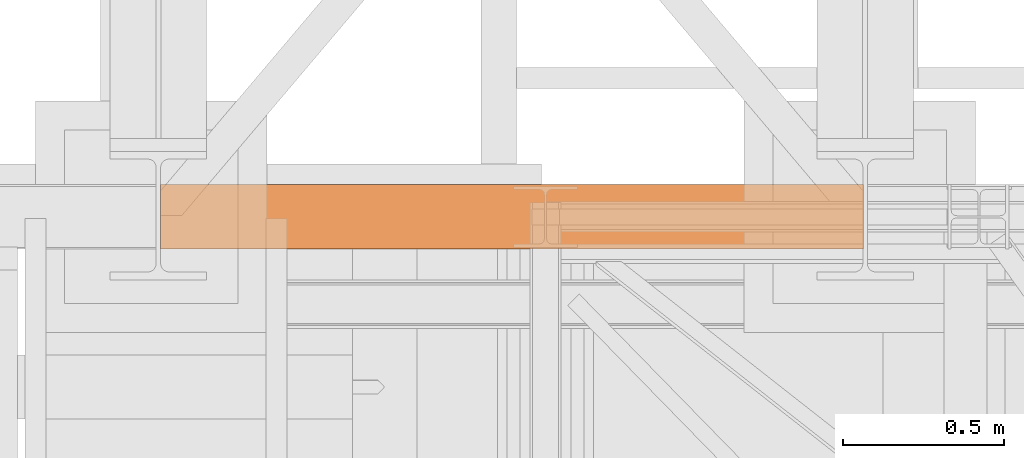
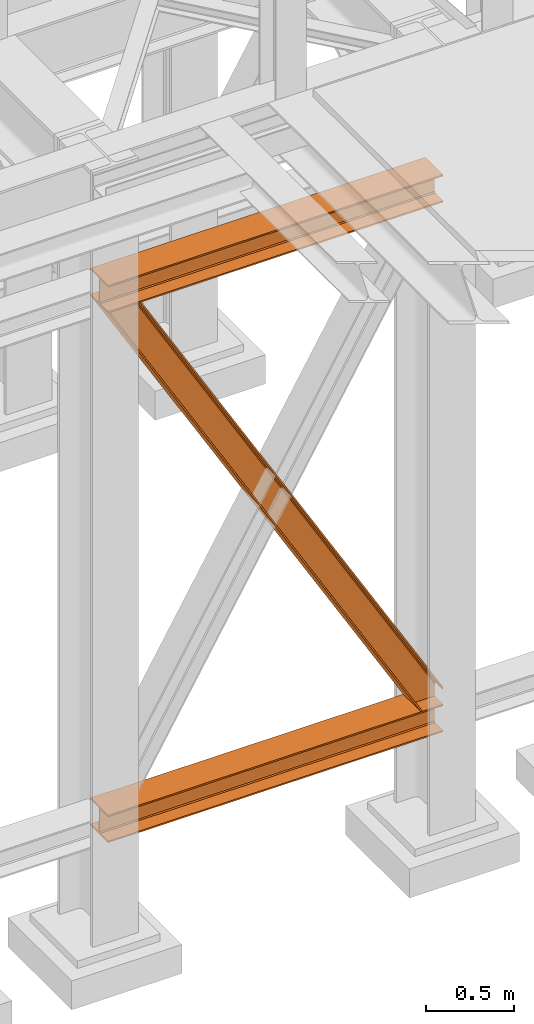
# One storey, part 32 of 208: 3 proxies.
"""IFC2X3 building model written with IfcOpenShell, lengths in millimetres."""

from ifc_helpers import new_model, entity, si_unit, converted_unit, frame, origin, origin_with_axes, place, context, subcontext, project, spatial, faceted_brep, element, save


model = new_model("IFC2X3")

# Units and contexts
model_context = context("Model", 3, precision=1e-05, world=origin())
plan_context = context("Plan", 3, precision=1e-05, world=origin())
body_context = subcontext(model_context, "Body", "Model", "MODEL_VIEW")
ifc_project = project(units=[si_unit("LENGTHUNIT", "METRE", prefix="MILLI"), converted_unit("PLANEANGLEUNIT", "DEGREE", entity("IfcPlaneAngleMeasure", 0.0174532925199433), si_unit("PLANEANGLEUNIT", "RADIAN"), dimensions=[0, 0, 0, 0, 0, 0, 0]), si_unit("AREAUNIT", "SQUARE_METRE"), si_unit("VOLUMEUNIT", "CUBIC_METRE")], contexts=[model_context, plan_context])

# Building, storey
building_placement = place(None, origin())
building = spatial("IfcBuilding", under=ifc_project, at=building_placement, CompositionType="COMPLEX")
storey_placement = place(building_placement, origin_with_axes())
storey = spatial("IfcBuildingStorey", under=building, at=storey_placement, Name="Geschoss", CompositionType="ELEMENT")

# Proxies
proxy_1_placement = place(storey_placement, frame((0.004974593445012943, -17362.5323246858, 544.9900024165573), z_axis=(0.0, 0.0, 1.0), x_axis=(1.0, 0.0, 0.0)))
element("IfcBuildingElementProxy", 1, at=proxy_1_placement, inside=storey, context=body_context, shape_type="Brep", body=[
    faceted_brep([(2188.009999895691, 0.00999999999839929, 190.0100125169756), (2188.009999895691, 200.0100029802306, 190.0100125169756), (2188.009999895691, 200.0100029802306, 180.0100146031382), (2188.009999895691, 121.2600035762771, 180.0100071525576), (2188.009999895691, 111.9441915473326, 178.1454621052744), (2188.009999895691, 105.1245498640819, 171.3258190250399), (2188.009999895691, 103.2600015571697, 162.010007927418), (2188.009999895691, 103.2600015571697, 28.00999713897727), (2188.009999895691, 105.1245498640819, 18.69418604135535), (2188.009999895691, 111.9441915473326, 11.87454296112082), (2188.009999895691, 121.2600035762771, 10.00999791383765), (2188.009999895691, 200.0100029802306, 10.00999791383765), (2188.009999895691, 200.0100029802306, 0.01000000000021828), (2188.009999895691, 0.00999999999839929, 0.01000000000021828), (2188.009999895691, 0.00999999999839929, 10.00999791383765), (2188.009999895691, 78.75999940395195, 10.00999791383765), (2188.009999895691, 88.07581143289644, 11.87454296112082), (2188.009999895691, 94.89545311614711, 18.69418604135535), (2188.009999895691, 96.7600014230593, 28.00999713897727), (2188.009999895691, 96.7600014230593, 162.010007927418), (2188.009999895691, 94.89545311614711, 171.3258190250399), (2188.009999895691, 88.07581143289644, 178.1454621052744), (2188.009999895691, 78.75999940395195, 180.0100071525576), (2188.009999895691, 0.00999999999839929, 180.0100146031382), (2188.009999895691, 200.0100029802306, 190.0100125169756), (2188.009999895691, 0.00999999999839929, 190.0100125169756), (0.009999999999990905, 0.00999999999839929, 190.0100125169755), (0.009999999999990905, 200.0100029802306, 190.0100125169755), (2188.009999895691, 200.0100029802306, 180.0100146031382), (2188.009999895691, 200.0100029802306, 190.0100125169756), (0.009999999999990905, 200.0100029802306, 190.0100125169755), (0.009999999999990905, 200.0100029802306, 180.0100146031381), (2188.009999895691, 121.2600035762771, 180.0100071525576), (2188.009999895691, 200.0100029802306, 180.0100146031382), (0.009999999999990905, 200.0100029802306, 180.0100146031381), (0.009999999999990905, 121.2600035762771, 180.0100071525575), (2188.009999895691, 111.9441915473326, 178.1454621052744), (2188.009999895691, 121.2600035762771, 180.0100071525576), (0.009999999999990905, 121.2600035762771, 180.0100071525575), (0.009999999999990905, 111.9441915473326, 178.1454621052743), (2188.009999895691, 105.1245498640819, 171.3258190250399), (2188.009999895691, 111.9441915473326, 178.1454621052744), (0.009999999999990905, 111.9441915473326, 178.1454621052743), (0.009999999999990905, 105.1245498640819, 171.3258190250398), (2188.009999895691, 103.2600015571697, 162.010007927418), (2188.009999895691, 105.1245498640819, 171.3258190250399), (0.009999999999990905, 105.1245498640819, 171.3258190250398), (0.009999999999990905, 103.2600015571697, 162.0100079274179), (2188.009999895691, 103.2600015571697, 28.00999713897727), (2188.009999895691, 103.2600015571697, 162.010007927418), (0.009999999999990905, 103.2600015571697, 162.0100079274179), (0.009999999999990905, 103.2600015571697, 28.00999713897716), (2188.009999895691, 105.1245498640819, 18.69418604135535), (2188.009999895691, 103.2600015571697, 28.00999713897727), (0.009999999999990905, 103.2600015571697, 28.00999713897716), (0.009999999999990905, 105.1245498640819, 18.69418604135524), (2188.009999895691, 111.9441915473326, 11.87454296112082), (2188.009999895691, 105.1245498640819, 18.69418604135535), (0.009999999999990905, 105.1245498640819, 18.69418604135524), (0.009999999999990905, 111.9441915473326, 11.87454296112071), (2188.009999895691, 121.2600035762771, 10.00999791383765), (2188.009999895691, 111.9441915473326, 11.87454296112082), (0.009999999999990905, 111.9441915473326, 11.87454296112071), (0.009999999999990905, 121.2600035762771, 10.00999791383754), (2188.009999895691, 200.0100029802306, 10.00999791383765), (2188.009999895691, 121.2600035762771, 10.00999791383765), (0.009999999999990905, 121.2600035762771, 10.00999791383754), (0.009999999999990905, 200.0100029802306, 10.00999791383754), (2188.009999895691, 200.0100029802306, 0.01000000000021828), (2188.009999895691, 200.0100029802306, 10.00999791383765), (0.009999999999990905, 200.0100029802306, 10.00999791383754), (0.009999999999990905, 200.0100029802306, 0.01000000000010459), (2188.009999895691, 0.00999999999839929, 0.01000000000021828), (2188.009999895691, 200.0100029802306, 0.01000000000021828), (0.009999999999990905, 200.0100029802306, 0.01000000000010459), (0.009999999999990905, 0.00999999999839929, 0.01000000000010459), (2188.009999895691, 0.00999999999839929, 10.00999791383765), (2188.009999895691, 0.00999999999839929, 0.01000000000021828), (0.009999999999990905, 0.00999999999839929, 0.01000000000010459), (0.009999999999990905, 0.00999999999839929, 10.00999791383754), (2188.009999895691, 78.75999940395195, 10.00999791383765), (2188.009999895691, 0.00999999999839929, 10.00999791383765), (0.009999999999990905, 0.00999999999839929, 10.00999791383754), (0.009999999999990905, 78.75999940395195, 10.00999791383754), (2188.009999895691, 88.07581143289644, 11.87454296112082), (2188.009999895691, 78.75999940395195, 10.00999791383765), (0.009999999999990905, 78.75999940395195, 10.00999791383754), (0.009999999999990905, 88.07581143289644, 11.87454296112071), (2188.009999895691, 94.89545311614711, 18.69418604135535), (2188.009999895691, 88.07581143289644, 11.87454296112082), (0.009999999999990905, 88.07581143289644, 11.87454296112071), (0.009999999999990905, 94.89545311614711, 18.69418604135524), (2188.009999895691, 96.7600014230593, 28.00999713897727), (2188.009999895691, 94.89545311614711, 18.69418604135535), (0.009999999999990905, 94.89545311614711, 18.69418604135524), (0.009999999999990905, 96.7600014230593, 28.00999713897716), (2188.009999895691, 96.7600014230593, 162.010007927418), (2188.009999895691, 96.7600014230593, 28.00999713897727), (0.009999999999990905, 96.7600014230593, 28.00999713897716), (0.009999999999990905, 96.7600014230593, 162.0100079274179), (2188.009999895691, 94.89545311614711, 171.3258190250399), (2188.009999895691, 96.7600014230593, 162.010007927418), (0.009999999999990905, 96.7600014230593, 162.0100079274179), (0.009999999999990905, 94.89545311614711, 171.3258190250398), (2188.009999895691, 88.07581143289644, 178.1454621052744), (2188.009999895691, 94.89545311614711, 171.3258190250399), (0.009999999999990905, 94.89545311614711, 171.3258190250398), (0.009999999999990905, 88.07581143289644, 178.1454621052743), (2188.009999895691, 78.75999940395195, 180.0100071525576), (2188.009999895691, 88.07581143289644, 178.1454621052744), (0.009999999999990905, 88.07581143289644, 178.1454621052743), (0.009999999999990905, 78.75999940395195, 180.0100071525575), (2188.009999895691, 0.00999999999839929, 180.0100146031382), (2188.009999895691, 78.75999940395195, 180.0100071525576), (0.009999999999990905, 78.75999940395195, 180.0100071525575), (0.009999999999990905, 0.00999999999839929, 180.0100146031381), (2188.009999895691, 0.00999999999839929, 190.0100125169756), (2188.009999895691, 0.00999999999839929, 180.0100146031382), (0.009999999999990905, 0.00999999999839929, 180.0100146031381), (0.009999999999990905, 0.00999999999839929, 190.0100125169755), (0.009999999999990905, 0.00999999999839929, 190.0100125169755), (0.009999999999990905, 0.00999999999839929, 180.0100146031381), (0.009999999999990905, 78.75999940395195, 180.0100071525575), (0.009999999999990905, 88.07581143289644, 178.1454621052743), (0.009999999999990905, 94.89545311614711, 171.3258190250398), (0.009999999999990905, 96.7600014230593, 162.0100079274179), (0.009999999999990905, 96.7600014230593, 28.00999713897716), (0.009999999999990905, 94.89545311614711, 18.69418604135524), (0.009999999999990905, 88.07581143289644, 11.87454296112071), (0.009999999999990905, 78.75999940395195, 10.00999791383754), (0.009999999999990905, 0.00999999999839929, 10.00999791383754), (0.009999999999990905, 0.00999999999839929, 0.01000000000010459), (0.009999999999990905, 200.0100029802306, 0.01000000000010459), (0.009999999999990905, 200.0100029802306, 10.00999791383754), (0.009999999999990905, 121.2600035762771, 10.00999791383754), (0.009999999999990905, 111.9441915473326, 11.87454296112071), (0.009999999999990905, 105.1245498640819, 18.69418604135524), (0.009999999999990905, 103.2600015571697, 28.00999713897716), (0.009999999999990905, 103.2600015571697, 162.0100079274179), (0.009999999999990905, 105.1245498640819, 171.3258190250398), (0.009999999999990905, 111.9441915473326, 178.1454621052743), (0.009999999999990905, 121.2600035762771, 180.0100071525575), (0.009999999999990905, 200.0100029802306, 180.0100146031381), (0.009999999999990905, 200.0100029802306, 190.0100125169755)], [[[0, 1, 2, 3, 4, 5, 6, 7, 8, 9, 10, 11, 12, 13, 14, 15, 16, 17, 18, 19, 20, 21, 22, 23]], [[24, 25, 26, 27]], [[28, 29, 30, 31]], [[32, 33, 34, 35]], [[36, 37, 38, 39]], [[40, 41, 42, 43]], [[44, 45, 46, 47]], [[48, 49, 50, 51]], [[52, 53, 54, 55]], [[56, 57, 58, 59]], [[60, 61, 62, 63]], [[64, 65, 66, 67]], [[68, 69, 70, 71]], [[72, 73, 74, 75]], [[76, 77, 78, 79]], [[80, 81, 82, 83]], [[84, 85, 86, 87]], [[88, 89, 90, 91]], [[92, 93, 94, 95]], [[96, 97, 98, 99]], [[100, 101, 102, 103]], [[104, 105, 106, 107]], [[108, 109, 110, 111]], [[112, 113, 114, 115]], [[116, 117, 118, 119]], [[120, 121, 122, 123, 124, 125, 126, 127, 128, 129, 130, 131, 132, 133, 134, 135, 136, 137, 138, 139, 140, 141, 142, 143]]], orient=[[False], [False], [False], [False], [False], [False], [False], [False], [False], [False], [False], [False], [False], [False], [False], [False], [False], [False], [False], [False], [False], [False], [False], [False], [False], [False]]),
])
proxy_2_placement = place(storey_placement, frame((0.004974593445012943, -17362.5323246858, 4202.989992847441), z_axis=(0.0, 0.0, 1.0), x_axis=(1.0, 0.0, 0.0)))
element("IfcBuildingElementProxy", 2, at=proxy_2_placement, inside=storey, context=body_context, shape_type="Brep", body=[
    faceted_brep([(2188.00999989569, 0.00999999999839929, 190.0100125169756), (2188.00999989569, 200.0100029802306, 190.0100125169756), (2188.00999989569, 200.0100029802306, 180.0100146031382), (2188.00999989569, 121.2600035762771, 180.0100071525576), (2188.00999989569, 111.9441915473326, 178.1454621052744), (2188.00999989569, 105.1245498640819, 171.3258190250399), (2188.00999989569, 103.2600015571697, 162.010007927418), (2188.00999989569, 103.2600015571697, 28.00999713897727), (2188.00999989569, 105.1245498640819, 18.69418604135535), (2188.00999989569, 111.9441915473326, 11.87454296112082), (2188.00999989569, 121.2600035762771, 10.00999791383765), (2188.00999989569, 200.0100029802306, 10.00999791383765), (2188.00999989569, 200.0100029802306, 0.01000000000021828), (2188.00999989569, 0.00999999999839929, 0.01000000000021828), (2188.00999989569, 0.00999999999839929, 10.00999791383765), (2188.00999989569, 78.75999940395195, 10.00999791383765), (2188.00999989569, 88.07581143289644, 11.87454296112082), (2188.00999989569, 94.89545311614711, 18.69418604135535), (2188.00999989569, 96.7600014230593, 28.00999713897727), (2188.00999989569, 96.7600014230593, 162.010007927418), (2188.00999989569, 94.89545311614711, 171.3258190250399), (2188.00999989569, 88.07581143289644, 178.1454621052744), (2188.00999989569, 78.75999940395195, 180.0100071525576), (2188.00999989569, 0.00999999999839929, 180.0100146031382), (2188.00999989569, 200.0100029802306, 190.0100125169756), (2188.00999989569, 0.00999999999839929, 190.0100125169756), (0.009999999999990905, 0.00999999999839929, 190.0100125169756), (0.009999999999990905, 200.0100029802306, 190.0100125169756), (2188.00999989569, 200.0100029802306, 180.0100146031382), (2188.00999989569, 200.0100029802306, 190.0100125169756), (0.009999999999990905, 200.0100029802306, 190.0100125169756), (0.009999999999990905, 200.0100029802306, 180.0100146031382), (2188.00999989569, 121.2600035762771, 180.0100071525576), (2188.00999989569, 200.0100029802306, 180.0100146031382), (0.009999999999990905, 200.0100029802306, 180.0100146031382), (0.009999999999990905, 121.2600035762771, 180.0100071525576), (2188.00999989569, 111.9441915473326, 178.1454621052744), (2188.00999989569, 121.2600035762771, 180.0100071525576), (0.009999999999990905, 121.2600035762771, 180.0100071525576), (0.009999999999990905, 111.9441915473326, 178.1454621052744), (2188.00999989569, 105.1245498640819, 171.3258190250399), (2188.00999989569, 111.9441915473326, 178.1454621052744), (0.009999999999990905, 111.9441915473326, 178.1454621052744), (0.009999999999990905, 105.1245498640819, 171.3258190250399), (2188.00999989569, 103.2600015571697, 162.010007927418), (2188.00999989569, 105.1245498640819, 171.3258190250399), (0.009999999999990905, 105.1245498640819, 171.3258190250399), (0.009999999999990905, 103.2600015571697, 162.010007927418), (2188.00999989569, 103.2600015571697, 28.00999713897727), (2188.00999989569, 103.2600015571697, 162.010007927418), (0.009999999999990905, 103.2600015571697, 162.010007927418), (0.009999999999990905, 103.2600015571697, 28.00999713897727), (2188.00999989569, 105.1245498640819, 18.69418604135535), (2188.00999989569, 103.2600015571697, 28.00999713897727), (0.009999999999990905, 103.2600015571697, 28.00999713897727), (0.009999999999990905, 105.1245498640819, 18.69418604135535), (2188.00999989569, 111.9441915473326, 11.87454296112082), (2188.00999989569, 105.1245498640819, 18.69418604135535), (0.009999999999990905, 105.1245498640819, 18.69418604135535), (0.009999999999990905, 111.9441915473326, 11.87454296112082), (2188.00999989569, 121.2600035762771, 10.00999791383765), (2188.00999989569, 111.9441915473326, 11.87454296112082), (0.009999999999990905, 111.9441915473326, 11.87454296112082), (0.009999999999990905, 121.2600035762771, 10.00999791383765), (2188.00999989569, 200.0100029802306, 10.00999791383765), (2188.00999989569, 121.2600035762771, 10.00999791383765), (0.009999999999990905, 121.2600035762771, 10.00999791383765), (0.009999999999990905, 200.0100029802306, 10.00999791383765), (2188.00999989569, 200.0100029802306, 0.01000000000021828), (2188.00999989569, 200.0100029802306, 10.00999791383765), (0.009999999999990905, 200.0100029802306, 10.00999791383765), (0.009999999999990905, 200.0100029802306, 0.01000000000021828), (2188.00999989569, 0.00999999999839929, 0.01000000000021828), (2188.00999989569, 200.0100029802306, 0.01000000000021828), (0.009999999999990905, 200.0100029802306, 0.01000000000021828), (0.009999999999990905, 0.00999999999839929, 0.01000000000021828), (2188.00999989569, 0.00999999999839929, 10.00999791383765), (2188.00999989569, 0.00999999999839929, 0.01000000000021828), (0.009999999999990905, 0.00999999999839929, 0.01000000000021828), (0.009999999999990905, 0.00999999999839929, 10.00999791383765), (2188.00999989569, 78.75999940395195, 10.00999791383765), (2188.00999989569, 0.00999999999839929, 10.00999791383765), (0.009999999999990905, 0.00999999999839929, 10.00999791383765), (0.009999999999990905, 78.75999940395195, 10.00999791383765), (2188.00999989569, 88.07581143289644, 11.87454296112082), (2188.00999989569, 78.75999940395195, 10.00999791383765), (0.009999999999990905, 78.75999940395195, 10.00999791383765), (0.009999999999990905, 88.07581143289644, 11.87454296112082), (2188.00999989569, 94.89545311614711, 18.69418604135535), (2188.00999989569, 88.07581143289644, 11.87454296112082), (0.009999999999990905, 88.07581143289644, 11.87454296112082), (0.009999999999990905, 94.89545311614711, 18.69418604135535), (2188.00999989569, 96.7600014230593, 28.00999713897727), (2188.00999989569, 94.89545311614711, 18.69418604135535), (0.009999999999990905, 94.89545311614711, 18.69418604135535), (0.009999999999990905, 96.7600014230593, 28.00999713897727), (2188.00999989569, 96.7600014230593, 162.010007927418), (2188.00999989569, 96.7600014230593, 28.00999713897727), (0.009999999999990905, 96.7600014230593, 28.00999713897727), (0.009999999999990905, 96.7600014230593, 162.010007927418), (2188.00999989569, 94.89545311614711, 171.3258190250399), (2188.00999989569, 96.7600014230593, 162.010007927418), (0.009999999999990905, 96.7600014230593, 162.010007927418), (0.009999999999990905, 94.89545311614711, 171.3258190250399), (2188.00999989569, 88.07581143289644, 178.1454621052744), (2188.00999989569, 94.89545311614711, 171.3258190250399), (0.009999999999990905, 94.89545311614711, 171.3258190250399), (0.009999999999990905, 88.07581143289644, 178.1454621052744), (2188.00999989569, 78.75999940395195, 180.0100071525576), (2188.00999989569, 88.07581143289644, 178.1454621052744), (0.009999999999990905, 88.07581143289644, 178.1454621052744), (0.009999999999990905, 78.75999940395195, 180.0100071525576), (2188.00999989569, 0.00999999999839929, 180.0100146031382), (2188.00999989569, 78.75999940395195, 180.0100071525576), (0.009999999999990905, 78.75999940395195, 180.0100071525576), (0.009999999999990905, 0.00999999999839929, 180.0100146031382), (2188.00999989569, 0.00999999999839929, 190.0100125169756), (2188.00999989569, 0.00999999999839929, 180.0100146031382), (0.009999999999990905, 0.00999999999839929, 180.0100146031382), (0.009999999999990905, 0.00999999999839929, 190.0100125169756), (0.009999999999990905, 0.00999999999839929, 190.0100125169756), (0.009999999999990905, 0.00999999999839929, 180.0100146031382), (0.009999999999990905, 78.75999940395195, 180.0100071525576), (0.009999999999990905, 88.07581143289644, 178.1454621052744), (0.009999999999990905, 94.89545311614711, 171.3258190250399), (0.009999999999990905, 96.7600014230593, 162.010007927418), (0.009999999999990905, 96.7600014230593, 28.00999713897727), (0.009999999999990905, 94.89545311614711, 18.69418604135535), (0.009999999999990905, 88.07581143289644, 11.87454296112082), (0.009999999999990905, 78.75999940395195, 10.00999791383765), (0.009999999999990905, 0.00999999999839929, 10.00999791383765), (0.009999999999990905, 0.00999999999839929, 0.01000000000021828), (0.009999999999990905, 200.0100029802306, 0.01000000000021828), (0.009999999999990905, 200.0100029802306, 10.00999791383765), (0.009999999999990905, 121.2600035762771, 10.00999791383765), (0.009999999999990905, 111.9441915473326, 11.87454296112082), (0.009999999999990905, 105.1245498640819, 18.69418604135535), (0.009999999999990905, 103.2600015571697, 28.00999713897727), (0.009999999999990905, 103.2600015571697, 162.010007927418), (0.009999999999990905, 105.1245498640819, 171.3258190250399), (0.009999999999990905, 111.9441915473326, 178.1454621052744), (0.009999999999990905, 121.2600035762771, 180.0100071525576), (0.009999999999990905, 200.0100029802306, 180.0100146031382), (0.009999999999990905, 200.0100029802306, 190.0100125169756)], [[[0, 1, 2, 3, 4, 5, 6, 7, 8, 9, 10, 11, 12, 13, 14, 15, 16, 17, 18, 19, 20, 21, 22, 23]], [[24, 25, 26, 27]], [[28, 29, 30, 31]], [[32, 33, 34, 35]], [[36, 37, 38, 39]], [[40, 41, 42, 43]], [[44, 45, 46, 47]], [[48, 49, 50, 51]], [[52, 53, 54, 55]], [[56, 57, 58, 59]], [[60, 61, 62, 63]], [[64, 65, 66, 67]], [[68, 69, 70, 71]], [[72, 73, 74, 75]], [[76, 77, 78, 79]], [[80, 81, 82, 83]], [[84, 85, 86, 87]], [[88, 89, 90, 91]], [[92, 93, 94, 95]], [[96, 97, 98, 99]], [[100, 101, 102, 103]], [[104, 105, 106, 107]], [[108, 109, 110, 111]], [[112, 113, 114, 115]], [[116, 117, 118, 119]], [[120, 121, 122, 123, 124, 125, 126, 127, 128, 129, 130, 131, 132, 133, 134, 135, 136, 137, 138, 139, 140, 141, 142, 143]]], orient=[[False], [False], [False], [False], [False], [False], [False], [False], [False], [False], [False], [False], [False], [False], [False], [False], [False], [False], [False], [False], [False], [False], [False], [False], [False], [False]]),
])
proxy_3_placement = place(storey_placement, frame((0.5824565525238086, -17362.5323246858, 734.9900149335328), z_axis=(0.0, 0.0, 1.0), x_axis=(1.0, 0.0, 0.0)))
element("IfcBuildingElementProxy", 3, at=proxy_3_placement, inside=storey, context=body_context, shape_type="Brep", body=[
    faceted_brep([(2187.432517936612, 0.00999999999839929, 120.8497915510925), (216.8471928951319, 0.00999999999839929, 3468.009977913908), (216.8471928951319, 200.0100029802306, 3468.009977913908), (2187.432517936612, 200.0100029802306, 120.8497915510925), (2187.432517936612, 200.0100029802306, 120.8497915510925), (216.8471928951319, 200.0100029802306, 3468.009977913908), (205.4347121912165, 200.0100029802306, 3468.009977913908), (2187.432517936612, 200.0100029802306, 101.4682129393399), (2187.432517936612, 200.0100029802306, 101.4682129393399), (205.4347121912165, 200.0100029802306, 3468.009977913908), (205.4347036882539, 121.2600035762771, 3468.009977913908), (2187.432517936951, 121.2600035762771, 101.4681984983712), (2187.432517936951, 121.2600035762771, 101.4681984983712), (205.4347036882539, 121.2600035762771, 3468.009977913908), (203.3067948069668, 111.9441915473326, 3468.009977913909), (2187.432602958225, 111.9441915473326, 97.8542740943027), (2187.432602958225, 111.9441915473326, 97.8542740943027), (203.3067948069668, 111.9441915473326, 3468.009977913909), (195.5238886772497, 105.1245498640819, 3468.009977913908), (2187.432517936612, 105.1245498640819, 84.63689245399053), (2187.432517936612, 105.1245498640819, 84.63689245399053), (195.5238886772497, 105.1245498640819, 3468.009977913908), (184.892235020021, 103.2600015571697, 3468.009977913908), (2187.432517936612, 103.2600015571697, 66.58142866151934), (2187.432517936612, 103.2600015571697, 0.01000000000010459), (2187.432517936612, 103.2600015571697, 66.58142866151934), (184.892235020021, 103.2600015571697, 3468.009977913908), (31.96494937214834, 103.2600015571697, 3468.009977913908), (2073.723887154785, 103.2600015571697, 0.01000000000033197), (2073.723887154785, 103.2600015571697, 0.01000000000033197), (31.96494937214834, 103.2600015571697, 3468.009977913908), (21.3332957149189, 105.1245498640819, 3468.009977913908), (2063.093996904378, 105.1245498640819, 0.01000000000021828), (2063.093996904378, 105.1245498640819, 0.01000000000021828), (21.3332957149189, 105.1245498640819, 3468.009977913908), (13.55038958520231, 111.9441915473326, 3468.009977913908), (2055.312379673187, 111.9441915473326, 0.009999999999877218), (2055.312379673187, 111.9441915473326, 0.009999999999877218), (13.55038958520231, 111.9441915473326, 3468.009977913908), (11.42248070391565, 121.2600035762771, 3468.009977913907), (2053.184822892688, 121.2600035762771, 0.009999999999877218), (2053.184822892688, 121.2600035762771, 0.009999999999877218), (11.42248070391565, 121.2600035762771, 3468.009977913907), (11.42248070391611, 200.0100029802306, 3468.009977913907), (2053.184822892688, 200.0100029802306, 0.009999999999877218), (2053.184822892688, 200.0100029802306, 0.009999999999877218), (11.42248070391611, 200.0100029802306, 3468.009977913907), (0.009999999999990905, 200.0100029802306, 3468.009977913908), (2041.774228435658, 200.0100029802306, 0.01000000000010459), (2041.774228435658, 200.0100029802306, 0.01000000000010459), (0.009999999999990905, 200.0100029802306, 3468.009977913908), (0.009999999999990905, 0.00999999999839929, 3468.009977913908), (2041.774228435658, 0.00999999999839929, 0.01000000000010459), (2041.774228435658, 0.00999999999839929, 0.01000000000010459), (0.009999999999990905, 0.00999999999839929, 3468.009977913908), (11.42248070391656, 0.00999999999839929, 3468.009977913908), (2053.184822892688, 0.00999999999839929, 0.009999999999990905), (2053.184822892688, 0.00999999999839929, 0.009999999999990905), (11.42248070391656, 0.00999999999839929, 3468.009977913908), (11.42248070391611, 78.75999940395195, 3468.009977913907), (2053.184822892688, 78.75999940395195, 0.009999999999877218), (2053.184822892688, 78.75999940395195, 0.009999999999877218), (11.42248070391611, 78.75999940395195, 3468.009977913907), (13.55038958520231, 88.07581143290008, 3468.009977913908), (2055.312379673187, 88.07581143289644, 0.009999999999877218), (2055.312379673187, 88.07581143289644, 0.009999999999877218), (13.55038958520231, 88.07581143290008, 3468.009977913908), (21.3332957149189, 94.89545311614711, 3468.009977913908), (2063.093996904378, 94.89545311614711, 0.009999999999877218), (2063.093996904378, 94.89545311614711, 0.009999999999877218), (21.3332957149189, 94.89545311614711, 3468.009977913908), (31.96494937214834, 96.7600014230593, 3468.009977913908), (2073.723887154785, 96.7600014230593, 0.01000000000033197), (2073.723887154785, 96.7600014230593, 0.01000000000033197), (31.96494937214834, 96.7600014230593, 3468.009977913908), (184.892235020021, 96.7600014230593, 3468.009977913908), (2187.432517936612, 96.7600014230593, 66.581428661519), (2187.432517936612, 96.7600014230593, 0.01000000000010459), (2187.432517936612, 96.7600014230593, 66.581428661519), (184.892235020021, 96.7600014230593, 3468.009977913908), (195.5238886772497, 94.89545311614711, 3468.009977913908), (2187.432517936612, 94.89545311615075, 84.63689245399053), (2187.432517936612, 94.89545311615075, 84.63689245399053), (195.5238886772497, 94.89545311614711, 3468.009977913908), (203.3067948069668, 88.07581143289644, 3468.009977913909), (2187.432517936612, 88.07581143289644, 97.85441850857103), (2187.432517936612, 88.07581143289644, 97.85441850857103), (203.3067948069668, 88.07581143289644, 3468.009977913909), (205.4347036882541, 78.75999940395195, 3468.009977913908), (2187.432433072335, 78.75999940395195, 101.4683426459952), (2187.432433072335, 78.75999940395195, 101.4683426459952), (205.4347036882541, 78.75999940395195, 3468.009977913908), (205.4347121912165, 0.00999999999839929, 3468.009977913908), (2187.432517936272, 0.00999999999839929, 101.4682129399165), (2187.432517936272, 0.00999999999839929, 101.4682129399165), (205.4347121912165, 0.00999999999839929, 3468.009977913908), (216.8471928951319, 0.00999999999839929, 3468.009977913908), (2187.432517936612, 0.00999999999839929, 120.8497915510925), (216.8471928951319, 0.00999999999839929, 3468.009977913908), (205.4347121912165, 0.00999999999839929, 3468.009977913908), (205.4347036882541, 78.75999940395195, 3468.009977913908), (203.3067948069668, 88.07581143289644, 3468.009977913909), (195.5238886772497, 94.89545311614711, 3468.009977913908), (184.892235020021, 96.7600014230593, 3468.009977913908), (31.96494937214834, 96.7600014230593, 3468.009977913908), (21.3332957149189, 94.89545311614711, 3468.009977913908), (13.55038958520231, 88.07581143290008, 3468.009977913908), (11.42248070391611, 78.75999940395195, 3468.009977913907), (11.42248070391656, 0.00999999999839929, 3468.009977913908), (0.009999999999990905, 0.00999999999839929, 3468.009977913908), (0.009999999999990905, 200.0100029802306, 3468.009977913908), (11.42248070391611, 200.0100029802306, 3468.009977913907), (11.42248070391565, 121.2600035762771, 3468.009977913907), (13.55038958520231, 111.9441915473326, 3468.009977913908), (21.3332957149189, 105.1245498640819, 3468.009977913908), (31.96494937214834, 103.2600015571697, 3468.009977913908), (184.892235020021, 103.2600015571697, 3468.009977913908), (195.5238886772497, 105.1245498640819, 3468.009977913908), (203.3067948069668, 111.9441915473326, 3468.009977913909), (205.4347036882539, 121.2600035762771, 3468.009977913908), (205.4347121912165, 200.0100029802306, 3468.009977913908), (216.8471928951319, 200.0100029802306, 3468.009977913908), (2187.432517936612, 96.7600014230593, 0.01000000000010459), (2187.432517936612, 96.7600014230593, 66.581428661519), (2187.432517936612, 94.89545311615075, 84.63689245399053), (2187.432517936612, 88.07581143289644, 97.85441850857103), (2187.432433072335, 78.75999940395195, 101.4683426459952), (2187.432517936272, 0.00999999999839929, 101.4682129399165), (2187.432517936612, 0.00999999999839929, 120.8497915510925), (2187.432517936612, 200.0100029802306, 120.8497915510925), (2187.432517936612, 200.0100029802306, 101.4682129393399), (2187.432517936951, 121.2600035762771, 101.4681984983712), (2187.432602958225, 111.9441915473326, 97.8542740943027), (2187.432517936612, 105.1245498640819, 84.63689245399053), (2187.432517936612, 103.2600015571697, 66.58142866151934), (2187.432517936612, 103.2600015571697, 0.01000000000010459), (2073.723887154785, 103.2600015571697, 0.01000000000033197), (2063.093996904378, 105.1245498640819, 0.01000000000021828), (2055.312379673187, 111.9441915473326, 0.009999999999877218), (2053.184822892688, 121.2600035762771, 0.009999999999877218), (2053.184822892688, 200.0100029802306, 0.009999999999877218), (2041.774228435658, 200.0100029802306, 0.01000000000010459), (2041.774228435658, 0.00999999999839929, 0.01000000000010459), (2053.184822892688, 0.00999999999839929, 0.009999999999990905), (2053.184822892688, 78.75999940395195, 0.009999999999877218), (2055.312379673187, 88.07581143289644, 0.009999999999877218), (2063.093996904378, 94.89545311614711, 0.009999999999877218), (2073.723887154785, 96.7600014230593, 0.01000000000033197), (2187.432517936612, 96.7600014230593, 0.01000000000010459), (2187.432517936612, 103.2600015571697, 0.01000000000010459)], [[[0, 1, 2, 3]], [[4, 5, 6, 7]], [[8, 9, 10, 11]], [[12, 13, 14, 15]], [[16, 17, 18, 19]], [[20, 21, 22, 23]], [[24, 25, 26, 27, 28]], [[29, 30, 31, 32]], [[33, 34, 35, 36]], [[37, 38, 39, 40]], [[41, 42, 43, 44]], [[45, 46, 47, 48]], [[49, 50, 51, 52]], [[53, 54, 55, 56]], [[57, 58, 59, 60]], [[61, 62, 63, 64]], [[65, 66, 67, 68]], [[69, 70, 71, 72]], [[73, 74, 75, 76, 77]], [[78, 79, 80, 81]], [[82, 83, 84, 85]], [[86, 87, 88, 89]], [[90, 91, 92, 93]], [[94, 95, 96, 97]], [[98, 99, 100, 101, 102, 103, 104, 105, 106, 107, 108, 109, 110, 111, 112, 113, 114, 115, 116, 117, 118, 119, 120, 121]], [[122, 123, 124, 125, 126, 127, 128, 129, 130, 131, 132, 133, 134, 135]], [[136, 137, 138, 139, 140, 141, 142, 143, 144, 145, 146, 147, 148, 149]]], orient=[[False], [False], [False], [False], [False], [False], [False], [False], [False], [False], [False], [False], [False], [False], [False], [False], [False], [False], [False], [False], [False], [False], [False], [False], [False], [False], [False]]),
])

save(model, "model.ifc")
